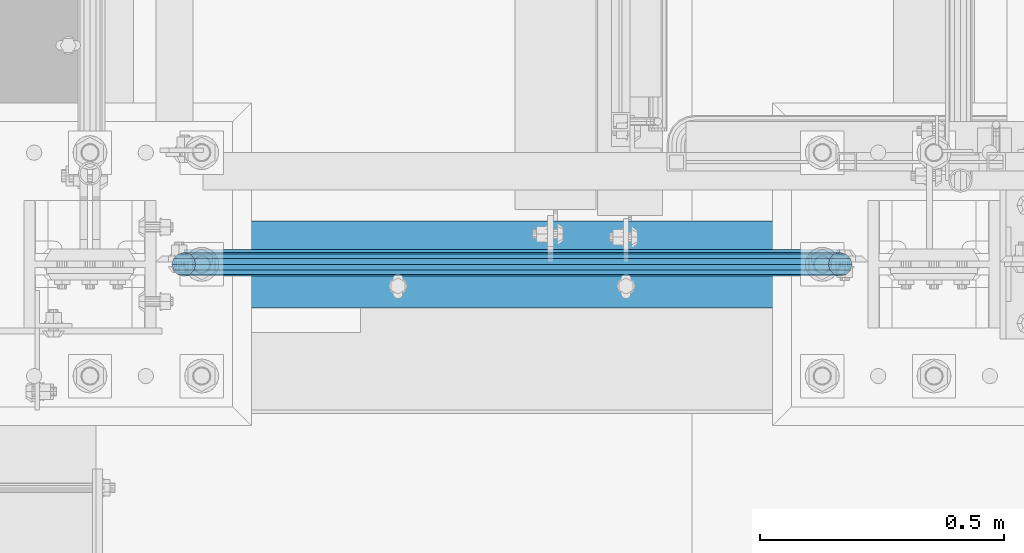
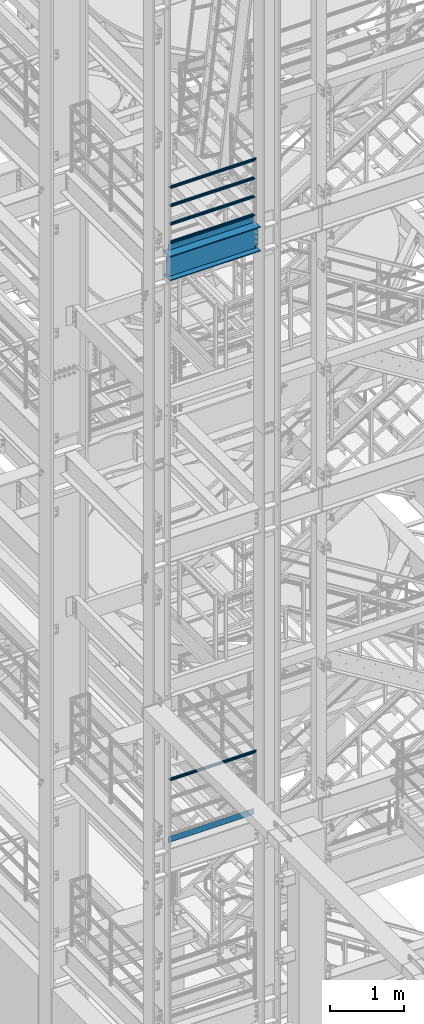
# One storey, part 931 of 1876: 8 beams, 3 elements without a shape of their own.
"""IFC2X3 building model written with IfcOpenShell, lengths in millimetres."""

from ifc_helpers import new_model, si_unit, frame, origin_with_axes, place, context, subcontext, project, spatial, faceted_brep, material, type_object, element, aggregate, save


model = new_model("IFC2X3")

# Units and contexts
model_context = context("Model", 3, precision=1e-05, world=origin_with_axes())
body_context = subcontext(model_context, "Body", "Model", "MODEL_VIEW")
ifc_project = project(units=[si_unit("LENGTHUNIT", "METRE", prefix="MILLI"), si_unit("AREAUNIT", "SQUARE_METRE"), si_unit("VOLUMEUNIT", "CUBIC_METRE"), si_unit("MASSUNIT", "GRAM", prefix="KILO"), si_unit("TIMEUNIT", "SECOND"), si_unit("PLANEANGLEUNIT", "RADIAN"), si_unit("SOLIDANGLEUNIT", "STERADIAN"), si_unit("THERMODYNAMICTEMPERATUREUNIT", "DEGREE_CELSIUS"), si_unit("LUMINOUSINTENSITYUNIT", "LUMEN")], contexts=[model_context])

# Site, building, storey
site_placement = place(None, origin_with_axes())
site = spatial("IfcSite", under=ifc_project, at=site_placement, CompositionType="ELEMENT")
building_placement = place(site_placement, origin_with_axes())
building = spatial("IfcBuilding", under=site, at=building_placement, Name="Undefined", CompositionType="ELEMENT")
storey_placement = place(building_placement, origin_with_axes())
storey = spatial("IfcBuildingStorey", under=building, at=storey_placement, Name="Undefined", CompositionType="ELEMENT", Elevation=0.0)

# Assembly, beam
assembly_1_placement = place(storey_placement, origin_with_axes())
assembly_1 = element("IfcElementAssembly", 1, at=assembly_1_placement, inside=storey, Name="RAIL", AssemblyPlace="NOTDEFINED", PredefinedType="RIGID_FRAME")
ifc_material_1 = material()
beam_type_1 = type_object("IfcBeamType", Name="PIPE1-1/2SCH40", PredefinedType="NOTDEFINED")
beam_1_placement = place(assembly_1_placement, frame((1559.2425, -7112.0, 9229.72499999999), z_axis=(0.0, 0.0, -1.0), x_axis=(-1.0, 0.0, 0.0)))
beam_1 = element("IfcBeam", 2, at=beam_1_placement, type_object=beam_type_1, material=ifc_material_1, Name="RAIL", ObjectType="PIPE1-1/2SCH40", context=body_context, shape_type="Brep", body=[
    faceted_brep([(24.1300000000001, -20.4469999999999, 0.0), (34.3535000000002, -17.7076214311803, 10.2235000000001), (1356.9315, -17.7076214311801, 10.2235000000001), (1367.155, -20.4470000000001, 0.0), (41.8376214311802, -10.2235000000001, 17.7076214311819), (1349.44737856882, -10.2235000000001, 17.7076214311801), (44.5770000000002, 0.0, 20.4470000000001), (1346.708, 0.0, 20.4470000000001), (41.8376214311802, 10.2235000000001, 17.7076214311819), (1349.44737856882, 10.2235000000001, 17.7076214311801), (34.3535000000002, 17.7076214311803, 10.2235000000001), (1356.9315, 17.7076214311801, 10.2235000000001), (24.1300000000001, 20.4469999999999, 0.0), (1367.155, 20.4470000000001, 0.0), (13.9065000000001, 17.7076214311803, -10.2235000000001), (1377.3785, 17.7076214311801, -10.2235000000001), (6.42237856882002, 10.2235000000001, -17.7076214311819), (1384.86262143118, 10.2235000000001, -17.7076214311801), (3.68299999999999, 0.0, -20.4470000000001), (1387.602, 0.0, -20.4470000000001), (6.42237856882002, -10.2235000000001, -17.7076214311819), (1384.86262143118, -10.2235000000001, -17.7076214311801), (13.9065000000001, -17.7076214311803, -10.2235000000001), (1377.3785, -17.7076214311801, -10.2235000000001), (24.1299999999854, -24.1299999999992, 0.0), (12.0650000000064, -20.8971929933177, -12.0649999999987), (1379.22, -20.8971929933186, -12.0649999999996), (1367.155, -24.1300000000001, 0.0), (3.23280700668147, -12.0650000000001, -20.8971929933177), (1388.05219299332, -12.0649999999996, -20.8971929933186), (-1.45519152283669e-11, 0.0, -24.130000000001), (1391.285, 0.0, -24.1300000000001), (3.23280700668147, 12.0650000000001, -20.8971929933177), (1388.05219299332, 12.0649999999996, -20.8971929933186), (12.0650000000064, 20.8971929933177, -12.0649999999987), (1379.22, 20.8971929933186, -12.0649999999996), (24.1300000000047, 24.1299999999992, 0.0), (1367.155, 24.1300000000001, 0.0), (36.1949999999997, 20.8971929933184, 12.0649999999987), (1355.09, 20.8971929933186, 12.0649999999996), (45.0271929933187, 12.0650000000001, 20.8971929933177), (1346.25780700668, 12.0649999999996, 20.8971929933186), (48.2600000000002, 0.0, 24.130000000001), (1343.025, 0.0, 24.1300000000001), (45.0271929933187, -12.0650000000001, 20.8971929933177), (1346.25780700668, -12.0649999999996, 20.8971929933186), (36.1949999999997, -20.8971929933184, 12.0649999999987), (1355.09, -20.8971929933186, 12.0649999999996)], [[[0, 1, 2, 3]], [[1, 4, 5, 2]], [[4, 6, 7, 5]], [[6, 8, 9, 7]], [[8, 10, 11, 9]], [[10, 12, 13, 11]], [[12, 14, 15, 13]], [[14, 16, 17, 15]], [[16, 18, 19, 17]], [[18, 20, 21, 19]], [[20, 22, 23, 21]], [[22, 0, 3, 23]], [[24, 25, 26, 27]], [[25, 28, 29, 26]], [[28, 30, 31, 29]], [[30, 32, 33, 31]], [[32, 34, 35, 33]], [[34, 36, 37, 35]], [[36, 38, 39, 37]], [[38, 40, 41, 39]], [[40, 42, 43, 41]], [[42, 44, 45, 43]], [[44, 46, 47, 45]], [[46, 24, 27, 47]], [[29, 31, 33, 35, 37, 39, 41, 43, 45, 47, 27, 26], [5, 7, 9, 11, 13, 15, 17, 19, 21, 23, 3, 2]], [[46, 44, 42, 40, 38, 36, 34, 32, 30, 28, 25, 24], [22, 20, 18, 16, 14, 12, 10, 8, 6, 4, 1, 0]]]),
])

# Assembly, beams
assembly_2_placement = place(storey_placement, origin_with_axes())
assembly_2 = element("IfcElementAssembly", 3, at=assembly_2_placement, inside=storey, Name="RAIL", AssemblyPlace="NOTDEFINED", PredefinedType="RIGID_FRAME")
beam_2_placement = place(assembly_2_placement, frame((192.0875, -7112.0, 18145.125), z_axis=(0.0, 0.0, 1.0), x_axis=(1.0, 0.0, 0.0)))
beam_2 = element("IfcBeam", 4, at=beam_2_placement, type_object=beam_type_1, material=ifc_material_1, Name="RAIL", ObjectType="PIPE1-1/2SCH40", context=body_context, shape_type="Brep", body=[
    faceted_brep([(1322.12780700668, -12.0649999999996, 20.8971929933186), (1322.12780700668, -12.0649999999996, 15.8661214311805), (1321.63437856882, -10.2235000000001, 17.7076214311801), (1318.895, 0.0, 20.4470000000001), (1318.895, 0.0, 24.1300000000001), (1321.63437856882, 10.2235000000001, 17.7076214311801), (1322.12780700668, 12.0649999999996, 15.8661214311805), (1322.12780700668, 12.0649999999996, 20.8971929933186), (1343.025, 24.1300000000001, 0.0), (1330.96, 20.8971929933186, 12.0649999999996), (1330.96, 20.8971929933186, -12.0649999999996), (1327.77042843786, 17.7076214311801, 10.2235000000001), (1330.50980700668, 20.4470000000001, 0.0), (1327.77042843786, 17.7076214311801, -10.2235000000001), (1322.12780700668, 12.0649999999996, -15.8661214311805), (1322.12780700668, 12.0649999999996, -20.8971929933186), (1321.63437856882, 10.2235000000001, -17.7076214311801), (1318.895, 0.0, -20.4470000000001), (1318.895, 0.0, -24.1300000000001), (1322.12780700668, -12.0649999999996, -15.8661214311805), (1322.12780700668, -12.0649999999996, -20.8971929933186), (1321.63437856882, -10.2235000000001, -17.7076214311801), (1343.025, -24.1300000000001, 0.0), (1330.96, -20.8971929933186, -12.0649999999996), (1330.96, -20.8971929933186, 12.0649999999996), (1327.77042843786, -17.7076214311801, -10.2235000000001), (1330.50980700668, -20.4470000000001, 0.0), (1327.77042843786, -17.7076214311801, 10.2235000000001), (12.0650000000064, -20.8971929933177, -12.0649999999987), (20.8971929933249, -12.0650000000005, -20.8971929933177), (0.0, 24.1299999999992, 0.0), (12.0650000000064, 20.8971929933177, -12.0649999999987), (12.0650000000064, 20.8971929933177, 12.0649999999987), (20.8971929933249, 12.0650000000005, 20.8971929933177), (24.1300000000064, 0.0, 24.130000000001), (20.8971929933249, 12.0650000000005, -20.8971929933177), (24.1300000000063, 0.0, -24.130000000001), (24.1300000000063, 0.0, -20.4470000000001), (20.8971929933249, -12.0650000000005, -15.8661214311796), (21.3906214311868, -10.2235000000001, -17.7076214311819), (21.3906214311868, 10.2235000000001, -17.7076214311819), (20.8971929933249, 12.0650000000005, -15.8661214311796), (15.2545715621445, 17.7076214311801, -10.2235000000001), (12.5151929933249, 20.4470000000001, 0.0), (15.2545715621445, 17.7076214311801, 10.2235000000001), (20.8971929933249, 12.0650000000005, 15.8661214311796), (21.3906214311868, 10.2235000000001, 17.7076214311819), (24.1300000000064, 0.0, 20.4470000000001), (21.3906214311868, -10.2235000000001, 17.7076214311819), (20.8971929933249, -12.0650000000005, 15.8661214311796), (20.8971929933249, -12.0650000000005, 20.8971929933177), (12.0650000000064, -20.8971929933177, 12.0649999999987), (0.0, -24.1299999999992, 0.0), (15.2545715621445, -17.7076214311801, 10.2235000000001), (12.5151929933249, -20.4470000000001, 0.0), (15.2545715621445, -17.7076214311801, -10.2235000000001)], [[[0, 1, 2, 3, 4]], [[4, 3, 5, 6, 7]], [[8, 9, 10]], [[7, 6, 11, 12, 13, 14, 15, 10, 9]], [[16, 17, 18, 15, 14]], [[19, 20, 18, 17, 21]], [[22, 23, 24]], [[24, 23, 20, 19, 25, 26, 27, 1, 0]], [[28, 29, 20, 23]], [[30, 31, 32]], [[33, 34, 4, 7]], [[32, 33, 7, 9]], [[30, 32, 9, 8]], [[31, 30, 8, 10]], [[35, 31, 10, 15]], [[36, 35, 15, 18]], [[29, 36, 18, 20]], [[37, 36, 29, 38, 39]], [[40, 41, 35, 36, 37]], [[32, 31, 35, 41, 42, 43, 44, 45, 33]], [[33, 45, 46, 47, 34]], [[34, 47, 48, 49, 50]], [[34, 50, 0, 4]], [[50, 51, 24, 0]], [[51, 52, 22, 24]], [[52, 28, 23, 22]], [[51, 28, 52]], [[50, 49, 53, 54, 55, 38, 29, 28, 51]], [[55, 54, 26, 25]], [[21, 39, 38, 55, 25, 19]], [[37, 39, 21, 17]], [[40, 37, 17, 16]], [[42, 41, 40, 16, 14, 13]], [[43, 42, 13, 12]], [[44, 43, 12, 11]], [[5, 46, 45, 44, 11, 6]], [[47, 46, 5, 3]], [[48, 47, 3, 2]], [[53, 49, 48, 2, 1, 27]], [[54, 53, 27, 26]]]),
])
beam_3_placement = place(assembly_2_placement, frame((1535.1125, -7112.0, 18449.925), z_axis=(0.0, 0.0, -1.0), x_axis=(-1.0, 0.0, 0.0)))
beam_3 = element("IfcBeam", 5, at=beam_3_placement, type_object=beam_type_1, material=ifc_material_1, Name="RAIL", ObjectType="PIPE1-1/2SCH40", context=body_context, shape_type="Brep", body=[
    faceted_brep([(0.0, 24.1299999999992, 0.0), (12.0650000000064, 20.8971929933177, -12.0649999999987), (12.0650000000064, 20.8971929933177, 12.0649999999987), (12.0650000000064, -20.8971929933177, 12.0649999999987), (12.0650000000064, -20.8971929933177, -12.0649999999987), (0.0, -24.1299999999992, 0.0), (20.8971929933249, -12.0650000000005, 20.8971929933177), (20.8971929933249, -12.0650000000005, 15.8661214311796), (15.2545715621445, -17.7076214311801, 10.2235000000001), (12.5151929933249, -20.4470000000001, 0.0), (15.2545715621445, -17.7076214311801, -10.2235000000001), (20.8971929933249, -12.0650000000005, -15.8661214311796), (20.8971929933249, -12.0650000000005, -20.8971929933177), (24.1300000000063, 0.0, -20.4470000000001), (24.1300000000063, 0.0, -24.130000000001), (21.3906214311868, -10.2235000000001, -17.7076214311819), (21.3906214311868, 10.2235000000001, -17.7076214311819), (20.8971929933249, 12.0650000000005, -15.8661214311796), (20.8971929933249, 12.0650000000005, -20.8971929933177), (15.2545715621445, 17.7076214311801, -10.2235000000001), (12.5151929933249, 20.4470000000001, 0.0), (15.2545715621445, 17.7076214311801, 10.2235000000001), (20.8971929933249, 12.0650000000005, 15.8661214311796), (20.8971929933249, 12.0650000000005, 20.8971929933177), (21.3906214311868, 10.2235000000001, 17.7076214311819), (24.1300000000064, 0.0, 20.4470000000001), (24.1300000000064, 0.0, 24.130000000001), (21.3906214311868, -10.2235000000001, 17.7076214311819), (1343.025, 24.1300000000001, 0.0), (1330.96, 20.8971929933186, -12.0649999999996), (1322.12780700668, 12.0649999999996, -20.8971929933186), (1343.025, -24.1300000000001, 0.0), (1330.96, -20.8971929933186, -12.0649999999996), (1330.96, -20.8971929933186, 12.0649999999996), (1322.12780700668, -12.0649999999996, 20.8971929933186), (1322.12780700668, -12.0649999999996, -20.8971929933186), (1318.895, 0.0, -24.1300000000001), (1321.63437856882, 10.2235000000001, -17.7076214311801), (1318.895, 0.0, -20.4470000000001), (1322.12780700668, 12.0649999999996, -15.8661214311805), (1322.12780700668, -12.0649999999996, -15.8661214311805), (1321.63437856882, -10.2235000000001, -17.7076214311801), (1327.77042843786, -17.7076214311801, -10.2235000000001), (1330.50980700668, -20.4470000000001, 0.0), (1327.77042843786, -17.7076214311801, 10.2235000000001), (1322.12780700668, -12.0649999999996, 15.8661214311805), (1321.63437856882, -10.2235000000001, 17.7076214311801), (1318.895, 0.0, 20.4470000000001), (1318.895, 0.0, 24.1300000000001), (1322.12780700668, 12.0649999999996, 20.8971929933186), (1330.96, 20.8971929933186, 12.0649999999996), (1322.12780700668, 12.0649999999996, 15.8661214311805), (1327.77042843786, 17.7076214311801, 10.2235000000001), (1330.50980700668, 20.4470000000001, 0.0), (1327.77042843786, 17.7076214311801, -10.2235000000001), (1321.63437856882, 10.2235000000001, 17.7076214311801)], [[[0, 1, 2]], [[3, 4, 5]], [[6, 7, 8, 9, 10, 11, 12, 4, 3]], [[13, 14, 12, 11, 15]], [[16, 17, 18, 14, 13]], [[2, 1, 18, 17, 19, 20, 21, 22, 23]], [[23, 22, 24, 25, 26]], [[26, 25, 27, 7, 6]], [[1, 0, 28, 29]], [[18, 1, 29, 30]], [[31, 32, 33]], [[6, 3, 33, 34]], [[3, 5, 31, 33]], [[5, 4, 32, 31]], [[4, 12, 35, 32]], [[12, 14, 36, 35]], [[14, 18, 30, 36]], [[37, 38, 36, 30, 39]], [[40, 35, 36, 38, 41]], [[33, 32, 35, 40, 42, 43, 44, 45, 34]], [[34, 45, 46, 47, 48]], [[26, 6, 34, 48]], [[2, 23, 49, 50]], [[23, 26, 48, 49]], [[0, 2, 50, 28]], [[28, 50, 29]], [[49, 51, 52, 53, 54, 39, 30, 29, 50]], [[48, 47, 55, 51, 49]], [[25, 24, 55, 47]], [[55, 24, 22, 21, 52, 51]], [[21, 20, 53, 52]], [[20, 19, 54, 53]], [[19, 17, 16, 37, 39, 54]], [[16, 13, 38, 37]], [[13, 15, 41, 38]], [[41, 15, 11, 10, 42, 40]], [[10, 9, 43, 42]], [[9, 8, 44, 43]], [[8, 7, 27, 46, 45, 44]], [[27, 25, 47, 46]]]),
])
beam_4_placement = place(assembly_2_placement, frame((1535.1125, -7112.0, 18754.725), z_axis=(0.0, 0.0, -1.0), x_axis=(-1.0, 0.0, 0.0)))
beam_4 = element("IfcBeam", 6, at=beam_4_placement, type_object=beam_type_1, material=ifc_material_1, Name="RAIL", ObjectType="PIPE1-1/2SCH40", context=body_context, shape_type="Brep", body=[
    faceted_brep([(0.0, 24.1299999999992, 0.0), (12.0650000000064, 20.8971929933177, -12.0649999999987), (12.0650000000064, 20.8971929933177, 12.0649999999987), (12.0650000000064, -20.8971929933177, 12.0649999999987), (12.0650000000064, -20.8971929933177, -12.0649999999987), (0.0, -24.1299999999992, 0.0), (20.8971929933249, -12.0650000000005, 20.8971929933177), (20.8971929933249, -12.0650000000005, 15.8661214311796), (15.2545715621445, -17.7076214311801, 10.2235000000001), (12.5151929933249, -20.4470000000001, 0.0), (15.2545715621445, -17.7076214311801, -10.2235000000001), (20.8971929933249, -12.0650000000005, -15.8661214311796), (20.8971929933249, -12.0650000000005, -20.8971929933177), (24.1300000000063, 0.0, -20.4470000000001), (24.1300000000063, 0.0, -24.130000000001), (21.3906214311868, -10.2235000000001, -17.7076214311819), (21.3906214311868, 10.2235000000001, -17.7076214311819), (20.8971929933249, 12.0650000000005, -15.8661214311796), (20.8971929933249, 12.0650000000005, -20.8971929933177), (15.2545715621445, 17.7076214311801, -10.2235000000001), (12.5151929933249, 20.4470000000001, 0.0), (15.2545715621445, 17.7076214311801, 10.2235000000001), (20.8971929933249, 12.0650000000005, 15.8661214311796), (20.8971929933249, 12.0650000000005, 20.8971929933177), (21.3906214311868, 10.2235000000001, 17.7076214311819), (24.1300000000064, 0.0, 20.4470000000001), (24.1300000000064, 0.0, 24.130000000001), (21.3906214311868, -10.2235000000001, 17.7076214311819), (1343.025, 24.1300000000001, 0.0), (1330.96, 20.8971929933186, -12.0649999999996), (1322.12780700668, 12.0649999999996, -20.8971929933186), (1343.025, -24.1300000000001, 0.0), (1330.96, -20.8971929933186, -12.0649999999996), (1330.96, -20.8971929933186, 12.0649999999996), (1322.12780700668, -12.0649999999996, 20.8971929933186), (1322.12780700668, -12.0649999999996, -20.8971929933186), (1318.895, 0.0, -24.1300000000001), (1321.63437856882, 10.2235000000001, -17.7076214311801), (1318.895, 0.0, -20.4470000000001), (1322.12780700668, 12.0649999999996, -15.8661214311805), (1322.12780700668, -12.0649999999996, -15.8661214311805), (1321.63437856882, -10.2235000000001, -17.7076214311801), (1327.77042843786, -17.7076214311801, -10.2235000000001), (1330.50980700668, -20.4470000000001, 0.0), (1327.77042843786, -17.7076214311801, 10.2235000000001), (1322.12780700668, -12.0649999999996, 15.8661214311805), (1321.63437856882, -10.2235000000001, 17.7076214311801), (1318.895, 0.0, 20.4470000000001), (1318.895, 0.0, 24.1300000000001), (1322.12780700668, 12.0649999999996, 20.8971929933186), (1330.96, 20.8971929933186, 12.0649999999996), (1322.12780700668, 12.0649999999996, 15.8661214311805), (1327.77042843786, 17.7076214311801, 10.2235000000001), (1330.50980700668, 20.4470000000001, 0.0), (1327.77042843786, 17.7076214311801, -10.2235000000001), (1321.63437856882, 10.2235000000001, 17.7076214311801)], [[[0, 1, 2]], [[3, 4, 5]], [[6, 7, 8, 9, 10, 11, 12, 4, 3]], [[13, 14, 12, 11, 15]], [[16, 17, 18, 14, 13]], [[2, 1, 18, 17, 19, 20, 21, 22, 23]], [[23, 22, 24, 25, 26]], [[26, 25, 27, 7, 6]], [[1, 0, 28, 29]], [[18, 1, 29, 30]], [[31, 32, 33]], [[6, 3, 33, 34]], [[3, 5, 31, 33]], [[5, 4, 32, 31]], [[4, 12, 35, 32]], [[12, 14, 36, 35]], [[14, 18, 30, 36]], [[37, 38, 36, 30, 39]], [[40, 35, 36, 38, 41]], [[33, 32, 35, 40, 42, 43, 44, 45, 34]], [[34, 45, 46, 47, 48]], [[26, 6, 34, 48]], [[2, 23, 49, 50]], [[23, 26, 48, 49]], [[0, 2, 50, 28]], [[28, 50, 29]], [[49, 51, 52, 53, 54, 39, 30, 29, 50]], [[48, 47, 55, 51, 49]], [[25, 24, 55, 47]], [[55, 24, 22, 21, 52, 51]], [[21, 20, 53, 52]], [[20, 19, 54, 53]], [[19, 17, 16, 37, 39, 54]], [[16, 13, 38, 37]], [[13, 15, 41, 38]], [[41, 15, 11, 10, 42, 40]], [[10, 9, 43, 42]], [[9, 8, 44, 43]], [[8, 7, 27, 46, 45, 44]], [[27, 25, 47, 46]]]),
])
beam_5_placement = place(assembly_2_placement, frame((1559.2425, -7112.0, 19059.525), z_axis=(0.0, 0.0, -1.0), x_axis=(-1.0, 0.0, 0.0)))
beam_5 = element("IfcBeam", 7, at=beam_5_placement, type_object=beam_type_1, material=ifc_material_1, Name="RAIL", ObjectType="PIPE1-1/2SCH40", context=body_context, shape_type="Brep", body=[
    faceted_brep([(24.1300000000001, -20.4469999999999, 0.0), (34.3535000000002, -17.7076214311803, 10.2235000000001), (1356.9315, -17.7076214311801, 10.2235000000001), (1367.155, -20.4470000000001, 0.0), (41.8376214311802, -10.2235000000001, 17.7076214311819), (1349.44737856882, -10.2235000000001, 17.7076214311801), (44.5770000000002, 0.0, 20.4470000000001), (1346.708, 0.0, 20.4470000000001), (41.8376214311802, 10.2235000000001, 17.7076214311819), (1349.44737856882, 10.2235000000001, 17.7076214311801), (34.3535000000002, 17.7076214311803, 10.2235000000001), (1356.9315, 17.7076214311801, 10.2235000000001), (24.1300000000001, 20.4469999999999, 0.0), (1367.155, 20.4470000000001, 0.0), (13.9065000000001, 17.7076214311803, -10.2235000000001), (1377.3785, 17.7076214311801, -10.2235000000001), (6.42237856882002, 10.2235000000001, -17.7076214311819), (1384.86262143118, 10.2235000000001, -17.7076214311801), (3.68299999999999, 0.0, -20.4470000000001), (1387.602, 0.0, -20.4470000000001), (6.42237856882002, -10.2235000000001, -17.7076214311819), (1384.86262143118, -10.2235000000001, -17.7076214311801), (13.9065000000001, -17.7076214311803, -10.2235000000001), (1377.3785, -17.7076214311801, -10.2235000000001), (24.1299999999854, -24.1299999999992, 0.0), (12.0650000000064, -20.8971929933177, -12.0649999999987), (1379.22, -20.8971929933186, -12.0649999999996), (1367.155, -24.1300000000001, 0.0), (3.23280700668147, -12.0650000000001, -20.8971929933177), (1388.05219299332, -12.0649999999996, -20.8971929933186), (-1.45519152283669e-11, 0.0, -24.130000000001), (1391.285, 0.0, -24.1300000000001), (3.23280700668147, 12.0650000000001, -20.8971929933177), (1388.05219299332, 12.0649999999996, -20.8971929933186), (12.0650000000064, 20.8971929933177, -12.0649999999987), (1379.22, 20.8971929933186, -12.0649999999996), (24.1300000000047, 24.1299999999992, 0.0), (1367.155, 24.1300000000001, 0.0), (36.1949999999997, 20.8971929933184, 12.0649999999987), (1355.09, 20.8971929933186, 12.0649999999996), (45.0271929933187, 12.0650000000001, 20.8971929933177), (1346.25780700668, 12.0649999999996, 20.8971929933186), (48.2600000000002, 0.0, 24.130000000001), (1343.025, 0.0, 24.1300000000001), (45.0271929933187, -12.0650000000001, 20.8971929933177), (1346.25780700668, -12.0649999999996, 20.8971929933186), (36.1949999999997, -20.8971929933184, 12.0649999999987), (1355.09, -20.8971929933186, 12.0649999999996)], [[[0, 1, 2, 3]], [[1, 4, 5, 2]], [[4, 6, 7, 5]], [[6, 8, 9, 7]], [[8, 10, 11, 9]], [[10, 12, 13, 11]], [[12, 14, 15, 13]], [[14, 16, 17, 15]], [[16, 18, 19, 17]], [[18, 20, 21, 19]], [[20, 22, 23, 21]], [[22, 0, 3, 23]], [[24, 25, 26, 27]], [[25, 28, 29, 26]], [[28, 30, 31, 29]], [[30, 32, 33, 31]], [[32, 34, 35, 33]], [[34, 36, 37, 35]], [[36, 38, 39, 37]], [[38, 40, 41, 39]], [[40, 42, 43, 41]], [[42, 44, 45, 43]], [[44, 46, 47, 45]], [[46, 24, 27, 47]], [[29, 31, 33, 35, 37, 39, 41, 43, 45, 47, 27, 26], [5, 7, 9, 11, 13, 15, 17, 19, 21, 23, 3, 2]], [[46, 44, 42, 40, 38, 36, 34, 32, 30, 28, 25, 24], [22, 20, 18, 16, 14, 12, 10, 8, 6, 4, 1, 0]]]),
])

# Beam
ifc_material_2 = material(Name="STEEL/A36")
beam_type_2 = type_object("IfcBeamType", PredefinedType="NOTDEFINED")
beam_6_placement = place(assembly_1_placement, frame((192.087499999998, -7085.0125, 8220.075), z_axis=(0.0, 0.0, 1.0), x_axis=(1.0, 0.0, 0.0)))
beam_6 = element("IfcBeam", 8, at=beam_6_placement, type_object=beam_type_2, material=ifc_material_2, Name="PLATE", context=body_context, shape_type="Brep", body=[
    faceted_brep([(0.0, 3.17500000000018, -50.8000000000002), (0.0, 3.17500000000018, 50.8000000000002), (1343.025, 3.17500000000018, 50.8000000000002), (1343.025, 3.17500000000018, -50.8000000000002), (0.0, -3.17500000000018, 50.8000000000002), (1343.025, -3.17500000000018, 50.8000000000002), (0.0, -3.17500000000018, -50.8000000000002), (1343.025, -3.17500000000018, -50.8000000000002)], [[[0, 1, 2, 3]], [[1, 4, 5, 2]], [[4, 6, 7, 5]], [[6, 0, 3, 7]], [[5, 7, 3, 2]], [[6, 4, 1, 0]]]),
])

aggregate(assembly_1, [beam_1, beam_6])

beam_7_placement = place(assembly_2_placement, frame((192.087499999998, -7085.0125, 18049.875), z_axis=(0.0, 0.0, 1.0), x_axis=(1.0, 0.0, 0.0)))
beam_7 = element("IfcBeam", 9, at=beam_7_placement, type_object=beam_type_2, material=ifc_material_2, Name="PLATE", context=body_context, shape_type="Brep", body=[
    faceted_brep([(0.0, 3.17500000000018, -50.8000000000002), (0.0, 3.17500000000018, 50.8000000000002), (1343.025, 3.17500000000018, 50.8000000000002), (1343.025, 3.17500000000018, -50.8000000000002), (0.0, -3.17500000000018, 50.8000000000002), (1343.025, -3.17500000000018, 50.8000000000002), (0.0, -3.17500000000018, -50.8000000000002), (1343.025, -3.17500000000018, -50.8000000000002)], [[[0, 1, 2, 3]], [[1, 4, 5, 2]], [[4, 6, 7, 5]], [[6, 0, 3, 7]], [[5, 7, 3, 2]], [[6, 4, 1, 0]]]),
])

aggregate(assembly_2, [beam_2, beam_3, beam_4, beam_5, beam_7])

# Assembly, beam
assembly_3_placement = place(storey_placement, origin_with_axes())
assembly_3 = element("IfcElementAssembly", 10, at=assembly_3_placement, inside=storey, Name="BEAM", AssemblyPlace="NOTDEFINED", PredefinedType="RIGID_FRAME")
ifc_material_3 = material(Name="STEEL/A992")
beam_type_3 = type_object("IfcBeamType", Name="W16X45", PredefinedType="NOTDEFINED")
beam_8_placement = place(assembly_3_placement, frame((0.0, -7112.0, 17778.4125), z_axis=(0.0, 0.0, 1.0), x_axis=(1.0, 0.0, 0.0)))
beam_8 = element("IfcBeam", 11, at=beam_8_placement, type_object=beam_type_3, material=ifc_material_3, Name="BEAM", ObjectType="W16X45", context=body_context, shape_type="Brep", body=[
    faceted_brep([(1582.7375, 4.76249999999982, 161.924999999999), (1573.21249970572, -4.76249999999982, 161.924999999999), (1573.21249970572, -4.76249999999982, -161.924999999999), (1582.7375, 4.76249999999982, -161.924999999999), (144.4625, 88.8999999999996, 190.5), (152.711099599373, 88.8999999999996, 204.787499999999), (1574.48890040062, 88.8999999999996, 204.787499999999), (1582.7375, 88.8999999999996, 190.5), (144.4625, 4.76249999999982, 190.5), (1582.7375, 4.76249999999982, 190.5), (152.711120260645, -88.8999999999996, -190.5), (144.4625, -88.8999999999996, -204.787499999999), (1582.7375, -88.8999999999996, -204.787499999999), (1574.48887973935, -88.8999999999996, -190.5), (144.4625, 88.8999999999996, -204.787499999999), (1582.7375, 88.8999999999996, -204.787499999999), (152.711120260645, 88.8999999999996, -190.5), (1574.48887973935, 88.8999999999996, -190.5), (152.711120260645, 4.76249999999982, -190.5), (1574.48887973935, 4.76249999999982, -190.5), (1530.71330732956, -4.76249999999982, -163.290718362852), (1530.71330732956, 4.76249999999982, -163.290718362852), (1535.62775003691, 4.76249999999982, -161.924999999999), (1535.62775003691, -4.76249999999982, -161.924999999999), (1527.20815489359, -4.76249999999982, -166.996233194965), (1527.20815489359, 4.76249999999982, -166.996233194965), (1526.11744784461, -4.76249999999982, -171.978932453771), (1526.11744784461, 4.76249999999982, -171.978932453771), (1527.75396281358, -4.76249999999982, -176.80995227641), (1527.75396281358, 4.76249999999982, -176.80995227641), (1531.64840454932, -4.76249999999982, -180.103925156887), (1531.64840454932, 4.76249999999982, -180.103925156887), (1553.39349932861, -4.76249999999982, -190.102999496459), (1553.39349932861, 4.76249999999982, -190.102999496459), (1574.25968949887, -4.76249999999982, -190.102999496459), (1574.25968949887, 4.76249999999982, -190.102999496459), (1574.48887973935, -4.76249999999982, -190.5), (152.711120260645, -4.76249999999982, -190.5), (152.940310501126, -4.76249999999982, -190.102999496459), (152.940310501126, 4.76249999999982, -190.102999496459), (173.806500671387, -4.76249999999982, -190.102999496459), (173.806500671387, 4.76249999999982, -190.102999496459), (195.551595450686, -4.76249999999982, -180.103925156884), (195.551595450686, 4.76249999999982, -180.103925156884), (199.446037186428, -4.76249999999982, -176.80995227641), (199.446037186428, 4.76249999999982, -176.80995227641), (201.082552155395, -4.76249999999982, -171.978932453767), (201.082552155395, 4.76249999999982, -171.978932453767), (199.991845106413, -4.76249999999982, -166.996233194965), (199.991845106413, 4.76249999999982, -166.996233194965), (196.486692670442, -4.76249999999982, -163.290718362852), (196.486692670442, 4.76249999999982, -163.290718362852), (191.572249963099, -4.76249999999982, -161.924999999999), (191.572249963099, 4.76249999999982, -161.924999999999), (153.987500294277, -4.76249999999982, -161.924999999996), (144.4625, 4.76249999999982, -161.924999999996), (153.987500294277, -4.7625002942832, 161.925000000003), (144.4625, 4.76249999999982, 161.925000000003), (190.80324988243, -4.76249999999982, 161.924999999999), (190.80324988243, 4.76249999999982, 161.924999999999), (195.717692628333, -4.76249999999982, 163.290718386077), (195.717692628333, 4.76249999999982, 163.290718386077), (199.22284506784, -4.76249999999982, 166.996233274545), (199.22284506784, 4.76249999999982, 166.996233274545), (200.313552067229, -4.76249999999982, 171.978932588601), (200.313552067229, 4.76249999999982, 171.978932588601), (198.677037004441, -4.76249999999982, 176.80995242525), (198.677037004441, 4.76249999999982, 176.80995242525), (194.782595165536, -4.76249999999982, 180.103925250914), (194.782595165536, 4.76249999999982, 180.103925250914), (173.037499237061, -4.76249999999982, 190.102999496463), (173.037499237061, 4.76249999999982, 190.102999496463), (144.4625, -4.76249999999982, 190.102999496463), (144.4625, 4.76249999999982, 190.102999496463), (144.4625, -4.76249999999982, 190.5), (152.711099599373, -88.8999999999996, 204.787499999999), (144.4625, -88.8999999999996, 190.5), (1582.7375, -4.76249999999982, 190.5), (1582.7375, -88.8999999999996, 190.5), (1574.48890040062, -88.8999999999996, 204.787499999999), (1582.7375, -4.76249999999982, 190.102999496459), (1582.7375, 4.76249999999982, 190.102999496459), (1554.16250076294, -4.76249999999982, 190.102999496459), (1554.16250076294, 4.76249999999982, 190.102999496459), (1532.41740483447, -4.76249999999982, 180.103925250914), (1532.41740483447, 4.76249999999982, 180.103925250914), (1528.52296299556, -4.76249999999982, 176.80995242525), (1528.52296299556, 4.76249999999982, 176.80995242525), (1526.88644793277, -4.76249999999982, 171.978932588601), (1526.88644793277, 4.76249999999982, 171.978932588601), (1527.97715493216, -4.76249999999982, 166.996233274542), (1527.97715493216, 4.76249999999982, 166.996233274542), (1531.48230737167, -4.76249999999982, 163.290718386077), (1531.48230737167, 4.76249999999982, 163.290718386077), (1536.39675011757, -4.76249999999982, 161.924999999999), (1536.39675011757, 4.76249999999982, 161.924999999999)], [[[0, 1, 2, 3]], [[4, 5, 6, 7]], [[8, 4, 7, 9]], [[10, 11, 12, 13]], [[11, 14, 15, 12]], [[14, 16, 17, 15]], [[16, 18, 19, 17]], [[20, 21, 22, 23]], [[24, 25, 21, 20]], [[26, 27, 25, 24]], [[28, 29, 27, 26]], [[30, 31, 29, 28]], [[32, 33, 31, 30]], [[33, 32, 34, 35]], [[12, 15, 17, 19, 35, 34, 36, 13]], [[37, 10, 13, 36]], [[38, 39, 18, 16, 14, 11, 10, 37]], [[40, 41, 39, 38]], [[42, 43, 41, 40]], [[44, 45, 43, 42]], [[46, 47, 45, 44]], [[48, 49, 47, 46]], [[50, 51, 49, 48]], [[52, 53, 51, 50]], [[53, 52, 54, 55]], [[56, 57, 55, 54]], [[58, 59, 57, 56]], [[60, 61, 59, 58]], [[62, 63, 61, 60]], [[64, 65, 63, 62]], [[66, 67, 65, 64]], [[68, 69, 67, 66]], [[70, 71, 69, 68]], [[71, 70, 72, 73]], [[73, 72, 74, 8]], [[75, 5, 4, 8, 74, 76]], [[76, 74, 77, 78]], [[75, 76, 78, 79]], [[5, 75, 79, 6]], [[78, 77, 9, 7, 6, 79]], [[80, 81, 9, 77]], [[82, 83, 81, 80]], [[84, 85, 83, 82]], [[86, 87, 85, 84]], [[88, 89, 87, 86]], [[90, 91, 89, 88]], [[92, 93, 91, 90]], [[94, 95, 93, 92]], [[22, 21, 25, 27, 29, 31, 33, 35, 19, 18, 39, 41, 43, 45, 47, 49, 51, 53, 55, 57, 59, 61, 63, 65, 67, 69, 71, 73, 8, 9, 81, 83, 85, 87, 89, 91, 93, 95, 0, 3]], [[23, 22, 3, 2]], [[94, 92, 90, 88, 86, 84, 82, 80, 77, 74, 72, 70, 68, 66, 64, 62, 60, 58, 56, 54, 52, 50, 48, 46, 44, 42, 40, 38, 37, 36, 34, 32, 30, 28, 26, 24, 20, 23, 2, 1]], [[95, 94, 1, 0]]]),
])
aggregate(assembly_3, [beam_8])

save(model, "model.ifc")
